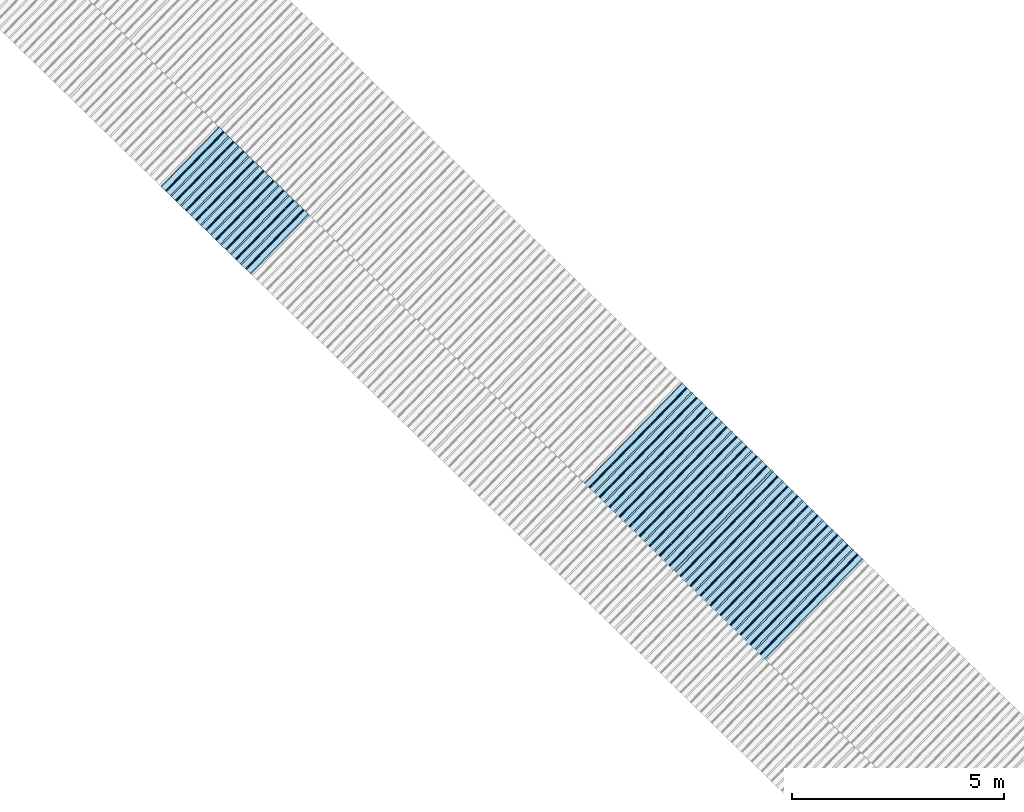
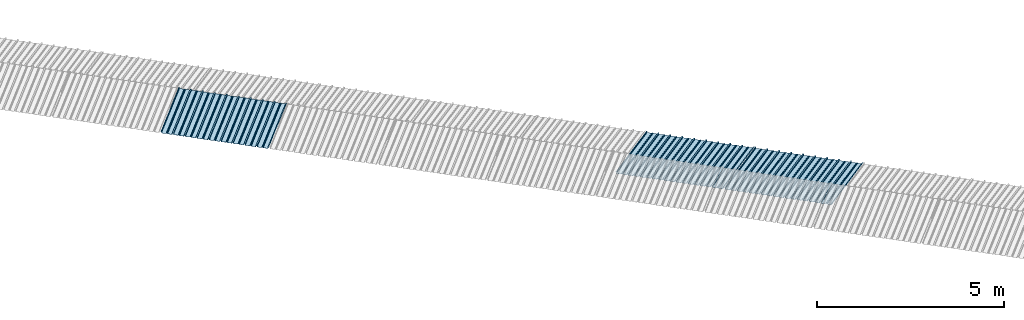
# One storey, part 5 of 8: 3 plates, 2 elements without a shape of their own.
"""IFC4 building model written with IfcOpenShell, lengths in metres."""

from ifc_helpers import new_model, entity, si_unit, converted_unit, direction, frame, origin, place, context, subcontext, project, spatial, line, arc, indexed_curve, outline, extrude, source, transform, mapped, material, type_object, type_shapes, element, aggregate, save


model = new_model("IFC4")

# Units and contexts
model_context = context("Model", 3, precision=1e-05, world=origin(), true_north=direction((6.123233995736766e-17, 1.0)))
body_context = subcontext(model_context, "Body", "Model", "MODEL_VIEW")
ifc_project = project(units=[si_unit("LENGTHUNIT", "METRE"), si_unit("AREAUNIT", "SQUARE_METRE"), si_unit("VOLUMEUNIT", "CUBIC_METRE"), converted_unit("PLANEANGLEUNIT", "DEGREE", entity("IfcPlaneAngleMeasure", 0.017453292519943278), si_unit("PLANEANGLEUNIT", "RADIAN"), dimensions=[0, 0, 0, 0, 0, 0, 0])], contexts=[model_context])

# Site, building, storey
site_placement = place(None, frame((0.0, 0.0, 0.0), z_axis=(0.0, 0.0, 1.0), x_axis=(0.7160934825303189, -0.6980043870045516, 0.0)))
site = spatial("IfcSite", under=ifc_project, at=site_placement, CompositionType="ELEMENT")
building_placement = place(site_placement, origin())
building = spatial("IfcBuilding", under=site, at=building_placement, CompositionType="ELEMENT")
storey_placement = place(building_placement, frame((0.0, 0.0, -1.24)))
storey = spatial("IfcBuildingStorey", under=building, at=storey_placement, Name="Livello 5", CompositionType="ELEMENT", Elevation=-1.24)

# Roof, plate
curtain_wall_type = type_object("IfcCurtainWallType", Name="Vetrata Copertura 2", PredefinedType="NOTDEFINED")
roof_1_placement = place(storey_placement, frame((0.0, 0.0, 1.24)))
roof_1 = element("IfcRoof", 1, at=roof_1_placement, inside=storey, type_object=curtain_wall_type, Name="Vetrata Copertura 2", ObjectType="Vetrata Copertura 2", PredefinedType="SHED_ROOF")
ifc_material = material(Name="Default")
plate_type_1 = type_object("IfcPlateType", Name="Pannello copertura:Pannello copertura", PredefinedType="CURTAIN_PANEL", material=ifc_material)
shared_shape_1 = source(origin(), body_context, "Body", "SweptSolid", [
    extrude(outline(indexed_curve([(1.339910560042256, -0.015785714285718594), (1.4699105600422562, -0.015785714285719003), (1.4699105600422562, 0.024214285714281004), (1.494919197675959, 0.02421428571428092), (1.494919197675959, 0.027214285714280917), (1.466910560042256, 0.027214285714281014), (1.466910560042256, -0.012785714285718995), (1.3417510978483753, -0.012785714285718492), (1.3199105600422556, 4.9134324369942785e-05), (1.2980700222361363, -0.012785714285718328), (1.1729105600422558, -0.01278571428571804), (1.1729105600422558, 0.02721428571428197), (1.136910560042256, 0.027214285714282097), (1.136910560042256, -0.012785714285717937), (1.0117510978483748, -0.01278571428571754), (0.9899105600422554, 4.913432437100935e-05), (0.968070022236136, -0.01278571428571726), (0.8429105600422558, -0.012785714285716971), (0.842910560042256, 0.027214285714283023), (0.8069105600422554, 0.027214285714283144), (0.8069105600422554, -0.01278571428571687), (0.6817510978483748, -0.012785714285716475), (0.6599105600422555, 4.9134324372075926e-05), (0.6380700222361361, -0.012785714285716196), (0.5129105600422553, -0.012785714285715915), (0.5129105600422554, 0.027214285714284105), (0.47691056004225557, 0.027214285714284227), (0.47691056004225557, -0.012785714285715804), (0.3517510978483749, -0.012785714285715427), (0.32991056004225544, 4.9134324373142496e-05), (0.3080700222361361, -0.012785714285715127), (0.18291056004225528, -0.012785714285714848), (0.18291056004225553, 0.027214285714285157), (0.1469105600422553, 0.02721428571428528), (0.14691056004225533, -0.012785714285714738), (0.021751097848374697, -0.01278571428571434), (-8.943995774469983e-05, 4.913432437420907e-05), (-0.021929977763864118, -0.01278571428571406), (-0.1470894399577447, -0.012785714285713783), (-0.14708943995774473, 0.02721428571428624), (-0.18308943995774493, 0.027214285714286364), (-0.1830894399577449, -0.012785714285713672), (-0.30824890215162537, -0.012785714285713215), (-0.33008943995774487, 4.9134324375275644e-05), (-0.3519299777638641, -0.012785714285712995), (-0.47708943995774494, -0.012785714285712714), (-0.4770894399577447, 0.02721428571428729), (-0.5130894399577449, 0.02721428571428741), (-0.5130894399577449, -0.012785714285712603), (-0.6382489021516256, -0.012785714285712207), (-0.6600894399577448, 4.9134324376342214e-05), (-0.6819299777638644, -0.012785714285711926), (-0.8070894399577453, -0.012785714285711647), (-0.807089439957745, 0.027214285714288373), (-0.843089439957745, 0.027214285714288494), (-0.8430894399577447, -0.012785714285711538), (-0.968248902151626, -0.012785714285711083), (-0.9900894399577453, 4.9134324377408785e-05), (-1.0119299777638646, -0.012785714285710861), (-1.1370894399577456, -0.012785714285710582), (-1.1370894399577451, 0.02721428571428942), (-1.1730894399577452, 0.027214285714289545), (-1.1730894399577454, -0.012785714285710473), (-1.2982489021516257, -0.012785714285710093), (-1.3200894399577452, 4.9134324378475355e-05), (-1.3419299777638647, -0.012785714285709794), (-1.4670894399577457, -0.012785714285709513), (-1.4670894399577454, 0.027214285714290503), (-1.490089439957745, 0.027214285714290586), (-1.490089439957745, 0.024214285714290556), (-1.4700894399577447, 0.02421428571429049), (-1.4700894399577449, -0.015785714285709514), (-1.3400894399577452, -0.015785714285709924), (-1.3200894399577452, -0.0029508656756215236), (-1.3000894399577452, -0.015785714285710063), (-1.170089439957745, -0.015785714285710472), (-1.1700894399577453, 0.024214285714289543), (-1.140089439957745, 0.02421428571428944), (-1.1400894399577455, -0.015785714285710583), (-1.0100894399577454, -0.015785714285710992), (-0.9900894399577453, -0.00295086567562259), (-0.9700894399577453, -0.015785714285711128), (-0.8400894399577448, -0.01578571428571154), (-0.8400894399577451, 0.024214285714288453), (-0.8100894399577452, 0.024214285714288356), (-0.8100894399577452, -0.015785714285711648), (-0.6800894399577451, -0.015785714285712012), (-0.6600894399577448, -0.0029508656756236573), (-0.6400894399577448, -0.015785714285712196), (-0.5100894399577451, -0.015785714285712606), (-0.5100894399577451, 0.024214285714287406), (-0.4800894399577449, 0.024214285714287305), (-0.4800894399577449, -0.015785714285712713), (-0.350089439957745, -0.01578571428571316), (-0.33008943995774487, -0.0029508656756247237), (-0.31008943995774485, -0.01578571428571326), (-0.1800894399577448, -0.015785714285713674), (-0.1800894399577448, 0.024214285714286323), (-0.1500894399577446, 0.02421428571428622), (-0.15008943995774485, -0.015785714285713782), (-0.020089439957744877, -0.015785714285714264), (-8.943995774473269e-05, -0.00295086567562579), (0.01991056004225521, -0.015785714285714323), (0.14991056004225545, -0.01578571428571474), (0.14991056004225542, 0.024214285714285272), (0.17991056004225567, 0.02421428571428517), (0.1799105600422554, -0.01578571428571485), (0.30991056004225526, -0.01578571428571532), (0.32991056004225544, -0.0029508656756268565), (0.3499105600422554, -0.015785714285715395), (0.47991056004225535, -0.015785714285715804), (0.47991056004225535, 0.02421428571428419), (0.5099105600422553, 0.02421428571428409), (0.5099105600422552, -0.015785714285715916), (0.6399105600422554, -0.015785714285716325), (0.6599105600422555, -0.002950865675627923), (0.6799105600422555, -0.01578571428571646), (0.8099105600422557, -0.015785714285716873), (0.8099105600422557, 0.02421428571428314), (0.8399105600422555, 0.02421428571428304), (0.8399105600422554, -0.015785714285716974), (0.9699105600422554, -0.015785714285717393), (0.9899105600422554, -0.0029508656756289894), (1.0099105600422555, -0.01578571428571753), (1.1399105600422557, -0.015785714285717938), (1.1399105600422557, 0.024214285714282077), (1.169910560042256, 0.024214285714281972), (1.1699105600422557, -0.01578571428571804), (1.2999105600422558, -0.01578571428571846), (1.3199105600422558, -0.0029508656756300567)], segments=[line(1, 2, 3, 4, 5, 6, 7, 8), arc(8, 9, 10), line(10, 11, 12, 13, 14, 15), arc(15, 16, 17), line(17, 18, 19, 20, 21, 22), arc(22, 23, 24), line(24, 25, 26, 27, 28, 29), arc(29, 30, 31), line(31, 32, 33, 34, 35, 36), arc(36, 37, 38), line(38, 39, 40, 41, 42, 43), arc(43, 44, 45), line(45, 46, 47, 48, 49, 50), arc(50, 51, 52), line(52, 53, 54, 55, 56, 57), arc(57, 58, 59), line(59, 60, 61, 62, 63, 64), arc(64, 65, 66), line(66, 67, 68, 69, 70, 71, 72, 73), arc(73, 74, 75), line(75, 76, 77, 78, 79, 80), arc(80, 81, 82), line(82, 83, 84, 85, 86, 87), arc(87, 88, 89), line(89, 90, 91, 92, 93, 94), arc(94, 95, 96), line(96, 97, 98, 99, 100, 101), arc(101, 102, 103), line(103, 104, 105, 106, 107, 108), arc(108, 109, 110), line(110, 111, 112, 113, 114, 115), arc(115, 116, 117), line(117, 118, 119, 120, 121, 122), arc(122, 123, 124), line(124, 125, 126, 127, 128, 129), arc(129, 130, 1)], self_intersect=False)), frame((8.080232403624576e-05, -0.015785714285719014, 0.0), z_axis=(0.0, 0.0, -1.0), x_axis=(1.0, 0.0, 0.0)), (0.0, 0.0, -1.0), 1.9691142879617602),
])
type_shapes(plate_type_1, [shared_shape_1])
plate_1_placement = place(roof_1_placement, frame((-17.232125184693174, -6.922854376535778, -1.0800000000000003), z_axis=(0.0, 0.9980594686585702, 0.0622679453729828), x_axis=(1.0, 0.0, 0.0)))
plate_1 = element("IfcPlate", 2, at=plate_1_placement, type_object=plate_type_1, material=ifc_material, Name="Pannello copertura:Pannello copertura", ObjectType="Pannello copertura:Pannello copertura", PredefinedType="CURTAIN_PANEL", context=body_context, shape_type="MappedRepresentation", body=[
    mapped(shared_shape_1, transform((0.0, 0.0, 0.0), scale=1.0)),
])
aggregate(roof_1, [plate_1])

# Roof, plates
roof_2_placement = place(storey_placement, frame((0.0, 0.0, 1.24)))
roof_2 = element("IfcRoof", 3, at=roof_2_placement, inside=storey, type_object=curtain_wall_type, Name="Vetrata Copertura 2", ObjectType="Vetrata Copertura 2", PredefinedType="SHED_ROOF")
plate_type_2 = type_object("IfcPlateType", Name="Pannello copertura:Pannello copertura", PredefinedType="CURTAIN_PANEL", material=ifc_material)
shared_shape_2 = source(origin(), body_context, "Body", "SweptSolid", [
    extrude(outline(indexed_curve([(1.339910560042256, -0.015785714285718594), (1.4699105600422562, -0.015785714285719003), (1.4699105600422562, 0.024214285714281004), (1.494919197675959, 0.02421428571428092), (1.494919197675959, 0.027214285714280917), (1.466910560042256, 0.027214285714281014), (1.466910560042256, -0.012785714285718995), (1.3417510978483753, -0.012785714285718492), (1.3199105600422556, 4.9134324369942785e-05), (1.2980700222361363, -0.012785714285718328), (1.1729105600422558, -0.01278571428571804), (1.1729105600422558, 0.02721428571428197), (1.136910560042256, 0.027214285714282097), (1.136910560042256, -0.012785714285717937), (1.0117510978483748, -0.01278571428571754), (0.9899105600422554, 4.913432437100935e-05), (0.968070022236136, -0.01278571428571726), (0.8429105600422558, -0.012785714285716971), (0.842910560042256, 0.027214285714283023), (0.8069105600422554, 0.027214285714283144), (0.8069105600422554, -0.01278571428571687), (0.6817510978483748, -0.012785714285716475), (0.6599105600422555, 4.9134324372075926e-05), (0.6380700222361361, -0.012785714285716196), (0.5129105600422553, -0.012785714285715915), (0.5129105600422554, 0.027214285714284105), (0.47691056004225557, 0.027214285714284227), (0.47691056004225557, -0.012785714285715804), (0.3517510978483749, -0.012785714285715427), (0.32991056004225544, 4.9134324373142496e-05), (0.3080700222361361, -0.012785714285715127), (0.18291056004225528, -0.012785714285714848), (0.18291056004225553, 0.027214285714285157), (0.1469105600422553, 0.02721428571428528), (0.14691056004225533, -0.012785714285714738), (0.021751097848374697, -0.01278571428571434), (-8.943995774469983e-05, 4.913432437420907e-05), (-0.021929977763864118, -0.01278571428571406), (-0.1470894399577447, -0.012785714285713783), (-0.14708943995774473, 0.02721428571428624), (-0.18308943995774493, 0.027214285714286364), (-0.1830894399577449, -0.012785714285713672), (-0.30824890215162537, -0.012785714285713215), (-0.33008943995774487, 4.9134324375275644e-05), (-0.3519299777638641, -0.012785714285712995), (-0.47708943995774494, -0.012785714285712714), (-0.4770894399577447, 0.02721428571428729), (-0.5130894399577449, 0.02721428571428741), (-0.5130894399577449, -0.012785714285712603), (-0.6382489021516256, -0.012785714285712207), (-0.6600894399577448, 4.9134324376342214e-05), (-0.6819299777638644, -0.012785714285711926), (-0.8070894399577453, -0.012785714285711647), (-0.807089439957745, 0.027214285714288373), (-0.843089439957745, 0.027214285714288494), (-0.8430894399577447, -0.012785714285711538), (-0.968248902151626, -0.012785714285711083), (-0.9900894399577453, 4.9134324377408785e-05), (-1.0119299777638646, -0.012785714285710861), (-1.1370894399577456, -0.012785714285710582), (-1.1370894399577451, 0.02721428571428942), (-1.1730894399577452, 0.027214285714289545), (-1.1730894399577454, -0.012785714285710473), (-1.2982489021516257, -0.012785714285710093), (-1.3200894399577452, 4.9134324378475355e-05), (-1.3419299777638647, -0.012785714285709794), (-1.4670894399577457, -0.012785714285709513), (-1.4670894399577454, 0.027214285714290503), (-1.490089439957745, 0.027214285714290586), (-1.490089439957745, 0.024214285714290556), (-1.4700894399577447, 0.02421428571429049), (-1.4700894399577449, -0.015785714285709514), (-1.3400894399577452, -0.015785714285709924), (-1.3200894399577452, -0.0029508656756215236), (-1.3000894399577452, -0.015785714285710063), (-1.170089439957745, -0.015785714285710472), (-1.1700894399577453, 0.024214285714289543), (-1.140089439957745, 0.02421428571428944), (-1.1400894399577455, -0.015785714285710583), (-1.0100894399577454, -0.015785714285710992), (-0.9900894399577453, -0.00295086567562259), (-0.9700894399577453, -0.015785714285711128), (-0.8400894399577448, -0.01578571428571154), (-0.8400894399577451, 0.024214285714288453), (-0.8100894399577452, 0.024214285714288356), (-0.8100894399577452, -0.015785714285711648), (-0.6800894399577451, -0.015785714285712012), (-0.6600894399577448, -0.0029508656756236573), (-0.6400894399577448, -0.015785714285712196), (-0.5100894399577451, -0.015785714285712606), (-0.5100894399577451, 0.024214285714287406), (-0.4800894399577449, 0.024214285714287305), (-0.4800894399577449, -0.015785714285712713), (-0.350089439957745, -0.01578571428571316), (-0.33008943995774487, -0.0029508656756247237), (-0.31008943995774485, -0.01578571428571326), (-0.1800894399577448, -0.015785714285713674), (-0.1800894399577448, 0.024214285714286323), (-0.1500894399577446, 0.02421428571428622), (-0.15008943995774485, -0.015785714285713782), (-0.020089439957744877, -0.015785714285714264), (-8.943995774473269e-05, -0.00295086567562579), (0.01991056004225521, -0.015785714285714323), (0.14991056004225545, -0.01578571428571474), (0.14991056004225542, 0.024214285714285272), (0.17991056004225567, 0.02421428571428517), (0.1799105600422554, -0.01578571428571485), (0.30991056004225526, -0.01578571428571532), (0.32991056004225544, -0.0029508656756268565), (0.3499105600422554, -0.015785714285715395), (0.47991056004225535, -0.015785714285715804), (0.47991056004225535, 0.02421428571428419), (0.5099105600422553, 0.02421428571428409), (0.5099105600422552, -0.015785714285715916), (0.6399105600422554, -0.015785714285716325), (0.6599105600422555, -0.002950865675627923), (0.6799105600422555, -0.01578571428571646), (0.8099105600422557, -0.015785714285716873), (0.8099105600422557, 0.02421428571428314), (0.8399105600422555, 0.02421428571428304), (0.8399105600422554, -0.015785714285716974), (0.9699105600422554, -0.015785714285717393), (0.9899105600422554, -0.0029508656756289894), (1.0099105600422555, -0.01578571428571753), (1.1399105600422557, -0.015785714285717938), (1.1399105600422557, 0.024214285714282077), (1.169910560042256, 0.024214285714281972), (1.1699105600422557, -0.01578571428571804), (1.2999105600422558, -0.01578571428571846), (1.3199105600422558, -0.0029508656756300567)], segments=[line(1, 2, 3, 4, 5, 6, 7, 8), arc(8, 9, 10), line(10, 11, 12, 13, 14, 15), arc(15, 16, 17), line(17, 18, 19, 20, 21, 22), arc(22, 23, 24), line(24, 25, 26, 27, 28, 29), arc(29, 30, 31), line(31, 32, 33, 34, 35, 36), arc(36, 37, 38), line(38, 39, 40, 41, 42, 43), arc(43, 44, 45), line(45, 46, 47, 48, 49, 50), arc(50, 51, 52), line(52, 53, 54, 55, 56, 57), arc(57, 58, 59), line(59, 60, 61, 62, 63, 64), arc(64, 65, 66), line(66, 67, 68, 69, 70, 71, 72, 73), arc(73, 74, 75), line(75, 76, 77, 78, 79, 80), arc(80, 81, 82), line(82, 83, 84, 85, 86, 87), arc(87, 88, 89), line(89, 90, 91, 92, 93, 94), arc(94, 95, 96), line(96, 97, 98, 99, 100, 101), arc(101, 102, 103), line(103, 104, 105, 106, 107, 108), arc(108, 109, 110), line(110, 111, 112, 113, 114, 115), arc(115, 116, 117), line(117, 118, 119, 120, 121, 122), arc(122, 123, 124), line(124, 125, 126, 127, 128, 129), arc(129, 130, 1)], self_intersect=False)), frame((8.080232403624576e-05, -0.015785714285719014, 0.0), z_axis=(0.0, 0.0, -1.0), x_axis=(1.0, 0.0, 0.0)), (0.0, 0.0, -1.0), 3.472878469300717),
])
type_shapes(plate_type_2, [shared_shape_2])
plate_2_placement = place(roof_2_placement, frame((-5.1748478447916755, -4.997561216564662, -1.6240000000000003), z_axis=(0.0, 0.9632563788424056, -0.26858359707810914), x_axis=(1.0, 0.0, 0.0)))
plate_2 = element("IfcPlate", 4, at=plate_2_placement, type_object=plate_type_2, material=ifc_material, Name="Pannello copertura:Pannello copertura", ObjectType="Pannello copertura:Pannello copertura", PredefinedType="CURTAIN_PANEL", context=body_context, shape_type="MappedRepresentation", body=[
    mapped(shared_shape_2, transform((0.0, 0.0, 0.0), scale=1.0)),
])
plate_type_3 = type_object("IfcPlateType", Name="Pannello copertura:Pannello copertura", PredefinedType="CURTAIN_PANEL", material=ifc_material)
shared_shape_3 = source(origin(), body_context, "Body", "SweptSolid", [
    extrude(outline(indexed_curve([(1.339910560042256, -0.015785714285718594), (1.4699105600422562, -0.015785714285719003), (1.4699105600422562, 0.024214285714281004), (1.494919197675959, 0.02421428571428092), (1.494919197675959, 0.027214285714280917), (1.466910560042256, 0.027214285714281014), (1.466910560042256, -0.012785714285718995), (1.3417510978483753, -0.012785714285718492), (1.3199105600422556, 4.9134324369942785e-05), (1.2980700222361363, -0.012785714285718328), (1.1729105600422558, -0.01278571428571804), (1.1729105600422558, 0.02721428571428197), (1.136910560042256, 0.027214285714282097), (1.136910560042256, -0.012785714285717937), (1.0117510978483748, -0.01278571428571754), (0.9899105600422554, 4.913432437100935e-05), (0.968070022236136, -0.01278571428571726), (0.8429105600422558, -0.012785714285716971), (0.842910560042256, 0.027214285714283023), (0.8069105600422554, 0.027214285714283144), (0.8069105600422554, -0.01278571428571687), (0.6817510978483748, -0.012785714285716475), (0.6599105600422555, 4.9134324372075926e-05), (0.6380700222361361, -0.012785714285716196), (0.5129105600422553, -0.012785714285715915), (0.5129105600422554, 0.027214285714284105), (0.47691056004225557, 0.027214285714284227), (0.47691056004225557, -0.012785714285715804), (0.3517510978483749, -0.012785714285715427), (0.32991056004225544, 4.9134324373142496e-05), (0.3080700222361361, -0.012785714285715127), (0.18291056004225528, -0.012785714285714848), (0.18291056004225553, 0.027214285714285157), (0.1469105600422553, 0.02721428571428528), (0.14691056004225533, -0.012785714285714738), (0.021751097848374697, -0.01278571428571434), (-8.943995774469983e-05, 4.913432437420907e-05), (-0.021929977763864118, -0.01278571428571406), (-0.1470894399577447, -0.012785714285713783), (-0.14708943995774473, 0.02721428571428624), (-0.18308943995774493, 0.027214285714286364), (-0.1830894399577449, -0.012785714285713672), (-0.30824890215162537, -0.012785714285713215), (-0.33008943995774487, 4.9134324375275644e-05), (-0.3519299777638641, -0.012785714285712995), (-0.47708943995774494, -0.012785714285712714), (-0.4770894399577447, 0.02721428571428729), (-0.5130894399577449, 0.02721428571428741), (-0.5130894399577449, -0.012785714285712603), (-0.6382489021516256, -0.012785714285712207), (-0.6600894399577448, 4.9134324376342214e-05), (-0.6819299777638644, -0.012785714285711926), (-0.8070894399577453, -0.012785714285711647), (-0.807089439957745, 0.027214285714288373), (-0.843089439957745, 0.027214285714288494), (-0.8430894399577447, -0.012785714285711538), (-0.968248902151626, -0.012785714285711083), (-0.9900894399577453, 4.9134324377408785e-05), (-1.0119299777638646, -0.012785714285710861), (-1.1370894399577456, -0.012785714285710582), (-1.1370894399577451, 0.02721428571428942), (-1.1730894399577452, 0.027214285714289545), (-1.1730894399577454, -0.012785714285710473), (-1.2982489021516257, -0.012785714285710093), (-1.3200894399577452, 4.9134324378475355e-05), (-1.3419299777638647, -0.012785714285709794), (-1.4670894399577457, -0.012785714285709513), (-1.4670894399577454, 0.027214285714290503), (-1.490089439957745, 0.027214285714290586), (-1.490089439957745, 0.024214285714290556), (-1.4700894399577447, 0.02421428571429049), (-1.4700894399577449, -0.015785714285709514), (-1.3400894399577452, -0.015785714285709924), (-1.3200894399577452, -0.0029508656756215236), (-1.3000894399577452, -0.015785714285710063), (-1.170089439957745, -0.015785714285710472), (-1.1700894399577453, 0.024214285714289543), (-1.140089439957745, 0.02421428571428944), (-1.1400894399577455, -0.015785714285710583), (-1.0100894399577454, -0.015785714285710992), (-0.9900894399577453, -0.00295086567562259), (-0.9700894399577453, -0.015785714285711128), (-0.8400894399577448, -0.01578571428571154), (-0.8400894399577451, 0.024214285714288453), (-0.8100894399577452, 0.024214285714288356), (-0.8100894399577452, -0.015785714285711648), (-0.6800894399577451, -0.015785714285712012), (-0.6600894399577448, -0.0029508656756236573), (-0.6400894399577448, -0.015785714285712196), (-0.5100894399577451, -0.015785714285712606), (-0.5100894399577451, 0.024214285714287406), (-0.4800894399577449, 0.024214285714287305), (-0.4800894399577449, -0.015785714285712713), (-0.350089439957745, -0.01578571428571316), (-0.33008943995774487, -0.0029508656756247237), (-0.31008943995774485, -0.01578571428571326), (-0.1800894399577448, -0.015785714285713674), (-0.1800894399577448, 0.024214285714286323), (-0.1500894399577446, 0.02421428571428622), (-0.15008943995774485, -0.015785714285713782), (-0.020089439957744877, -0.015785714285714264), (-8.943995774473269e-05, -0.00295086567562579), (0.01991056004225521, -0.015785714285714323), (0.14991056004225545, -0.01578571428571474), (0.14991056004225542, 0.024214285714285272), (0.17991056004225567, 0.02421428571428517), (0.1799105600422554, -0.01578571428571485), (0.30991056004225526, -0.01578571428571532), (0.32991056004225544, -0.0029508656756268565), (0.3499105600422554, -0.015785714285715395), (0.47991056004225535, -0.015785714285715804), (0.47991056004225535, 0.02421428571428419), (0.5099105600422553, 0.02421428571428409), (0.5099105600422552, -0.015785714285715916), (0.6399105600422554, -0.015785714285716325), (0.6599105600422555, -0.002950865675627923), (0.6799105600422555, -0.01578571428571646), (0.8099105600422557, -0.015785714285716873), (0.8099105600422557, 0.02421428571428314), (0.8399105600422555, 0.02421428571428304), (0.8399105600422554, -0.015785714285716974), (0.9699105600422554, -0.015785714285717393), (0.9899105600422554, -0.0029508656756289894), (1.0099105600422555, -0.01578571428571753), (1.1399105600422557, -0.015785714285717938), (1.1399105600422557, 0.024214285714282077), (1.169910560042256, 0.024214285714281972), (1.1699105600422557, -0.01578571428571804), (1.2999105600422558, -0.01578571428571846), (1.3199105600422558, -0.0029508656756300567)], segments=[line(1, 2, 3, 4, 5, 6, 7, 8), arc(8, 9, 10), line(10, 11, 12, 13, 14, 15), arc(15, 16, 17), line(17, 18, 19, 20, 21, 22), arc(22, 23, 24), line(24, 25, 26, 27, 28, 29), arc(29, 30, 31), line(31, 32, 33, 34, 35, 36), arc(36, 37, 38), line(38, 39, 40, 41, 42, 43), arc(43, 44, 45), line(45, 46, 47, 48, 49, 50), arc(50, 51, 52), line(52, 53, 54, 55, 56, 57), arc(57, 58, 59), line(59, 60, 61, 62, 63, 64), arc(64, 65, 66), line(66, 67, 68, 69, 70, 71, 72, 73), arc(73, 74, 75), line(75, 76, 77, 78, 79, 80), arc(80, 81, 82), line(82, 83, 84, 85, 86, 87), arc(87, 88, 89), line(89, 90, 91, 92, 93, 94), arc(94, 95, 96), line(96, 97, 98, 99, 100, 101), arc(101, 102, 103), line(103, 104, 105, 106, 107, 108), arc(108, 109, 110), line(110, 111, 112, 113, 114, 115), arc(115, 116, 117), line(117, 118, 119, 120, 121, 122), arc(122, 123, 124), line(124, 125, 126, 127, 128, 129), arc(129, 130, 1)], self_intersect=False)), frame((8.080232403624576e-05, -0.015785714285719014, 0.0), z_axis=(0.0, 0.0, -1.0), x_axis=(1.0, 0.0, 0.0)), (0.0, 0.0, -1.0), 3.472878469300717),
])
type_shapes(plate_type_3, [shared_shape_3])
plate_3_placement = place(roof_2_placement, frame((-2.174843093074386, -4.997561216564662, -1.6240000000000003), z_axis=(0.0, 0.9632563788424056, -0.26858359707810914), x_axis=(1.0, 0.0, 0.0)))
plate_3 = element("IfcPlate", 5, at=plate_3_placement, type_object=plate_type_3, material=ifc_material, Name="Pannello copertura:Pannello copertura", ObjectType="Pannello copertura:Pannello copertura", PredefinedType="CURTAIN_PANEL", context=body_context, shape_type="MappedRepresentation", body=[
    mapped(shared_shape_3, transform((0.0, 0.0, 0.0), scale=1.0)),
])
aggregate(roof_2, [plate_2, plate_3])

save(model, "model.ifc")
